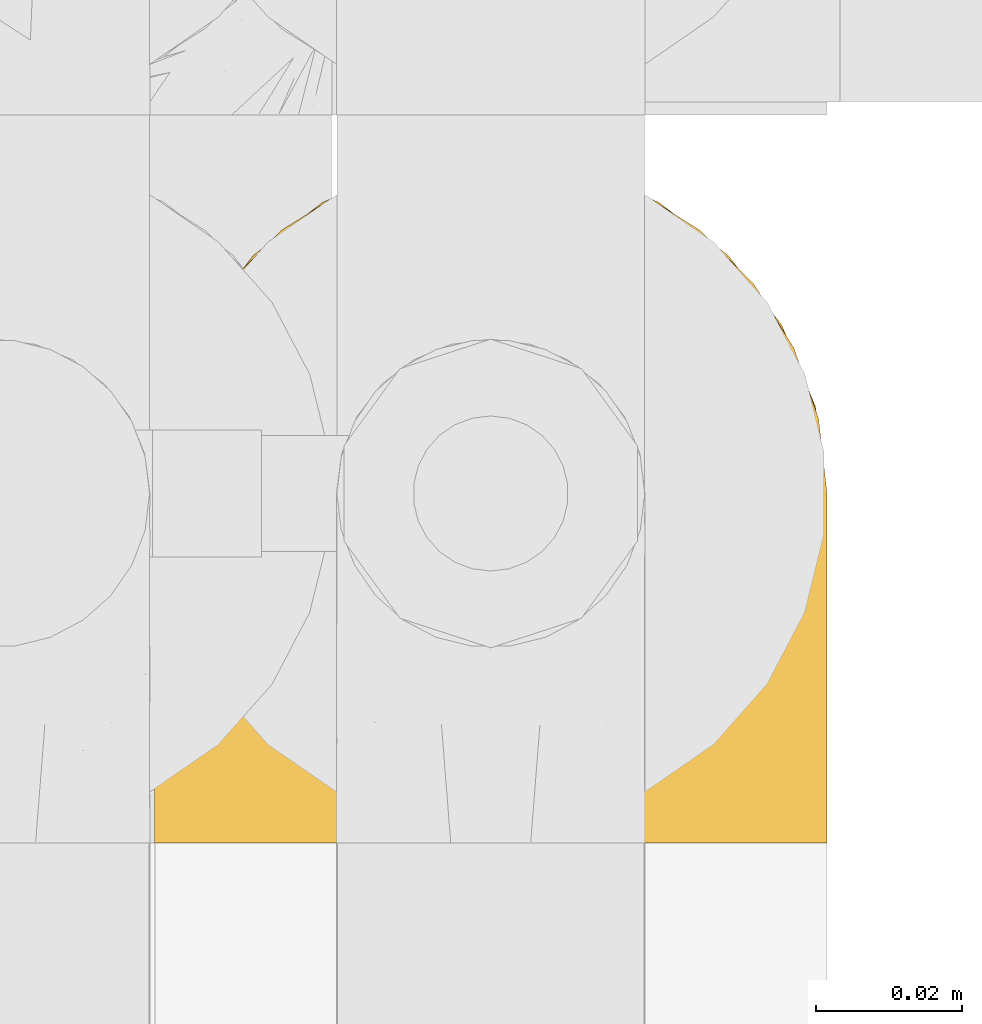
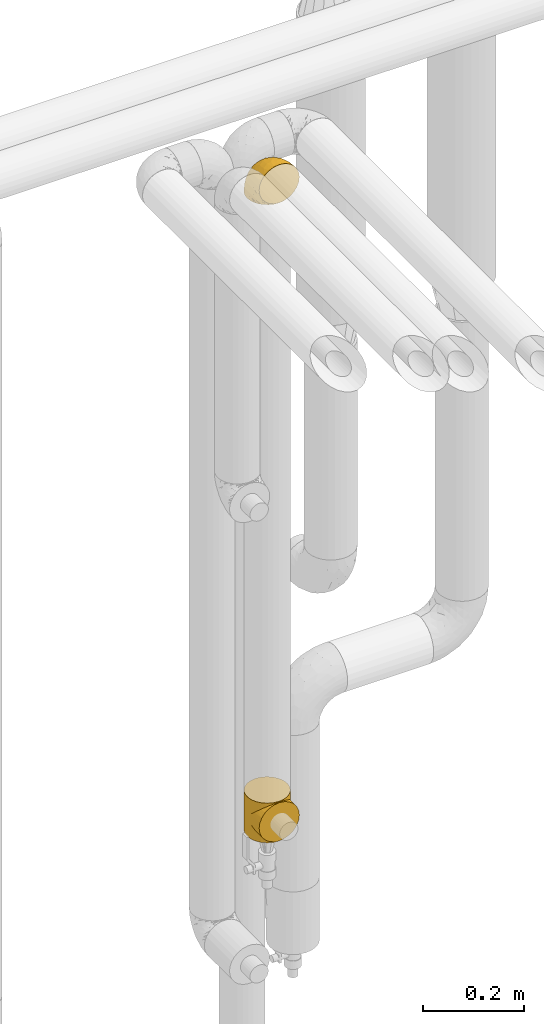
# One storey, part 308 of 827: 2 coverings.
"""IFC2X3 building model written with IfcOpenShell, lengths in millimetres."""

from ifc_helpers import new_model, entity, si_unit, converted_unit, derived_unit, direction, frame, origin, place, context, subcontext, project, spatial, faceted_brep, element, save


model = new_model("IFC2X3")

# Units and contexts
model_context = context("Model", 3, precision=0.01, world=origin(), true_north=direction((6.12303176911189e-17, 1.0)))
body_context = subcontext(model_context, "Body", "Model", "MODEL_VIEW")
ifc_project = project(units=[si_unit("LENGTHUNIT", "METRE", prefix="MILLI"), si_unit("AREAUNIT", "SQUARE_METRE"), si_unit("VOLUMEUNIT", "CUBIC_METRE"), converted_unit("PLANEANGLEUNIT", "DEGREE", entity("IfcRatioMeasure", 0.0174532925199433), si_unit("PLANEANGLEUNIT", "RADIAN"), dimensions=[0, 0, 0, 0, 0, 0, 0]), si_unit("MASSUNIT", "GRAM", prefix="KILO"), derived_unit("MASSDENSITYUNIT", [(si_unit("MASSUNIT", "GRAM", prefix="KILO"), 1), (si_unit("LENGTHUNIT", "METRE"), -3)]), derived_unit("MOMENTOFINERTIAUNIT", [(si_unit("LENGTHUNIT", "METRE"), 4)]), si_unit("TIMEUNIT", "SECOND"), si_unit("FREQUENCYUNIT", "HERTZ"), si_unit("THERMODYNAMICTEMPERATUREUNIT", "DEGREE_CELSIUS"), derived_unit("THERMALTRANSMITTANCEUNIT", [(si_unit("MASSUNIT", "GRAM", prefix="KILO"), 1), (si_unit("THERMODYNAMICTEMPERATUREUNIT", "KELVIN"), -1), (si_unit("TIMEUNIT", "SECOND"), -3)]), derived_unit("VOLUMETRICFLOWRATEUNIT", [(si_unit("LENGTHUNIT", "METRE"), 3), (si_unit("TIMEUNIT", "SECOND"), -1)]), derived_unit("MASSFLOWRATEUNIT", [(si_unit("MASSUNIT", "GRAM", prefix="KILO"), 1), (si_unit("TIMEUNIT", "SECOND"), -1)]), derived_unit("ROTATIONALFREQUENCYUNIT", [(si_unit("TIMEUNIT", "SECOND"), -1)]), si_unit("ELECTRICCURRENTUNIT", "AMPERE"), si_unit("ELECTRICVOLTAGEUNIT", "VOLT"), si_unit("POWERUNIT", "WATT"), si_unit("FORCEUNIT", "NEWTON", prefix="KILO"), si_unit("ILLUMINANCEUNIT", "LUX"), si_unit("LUMINOUSFLUXUNIT", "LUMEN"), si_unit("LUMINOUSINTENSITYUNIT", "CANDELA"), derived_unit("USERDEFINED", [(si_unit("MASSUNIT", "GRAM", prefix="KILO"), -1), (si_unit("LENGTHUNIT", "METRE"), -2), (si_unit("TIMEUNIT", "SECOND"), 3), (si_unit("LUMINOUSFLUXUNIT", "LUMEN"), 1)]), derived_unit("LINEARVELOCITYUNIT", [(si_unit("LENGTHUNIT", "METRE"), 1), (si_unit("TIMEUNIT", "SECOND"), -1)]), si_unit("PRESSUREUNIT", "PASCAL"), derived_unit("USERDEFINED", [(si_unit("LENGTHUNIT", "METRE"), -2), (si_unit("MASSUNIT", "GRAM", prefix="KILO"), 1), (si_unit("TIMEUNIT", "SECOND"), -2)]), derived_unit("LINEARFORCEUNIT", [(si_unit("MASSUNIT", "GRAM", prefix="KILO"), 1), (si_unit("LENGTHUNIT", "METRE"), 1), (si_unit("TIMEUNIT", "SECOND"), -2), (si_unit("LENGTHUNIT", "METRE"), -1)]), derived_unit("PLANARFORCEUNIT", [(si_unit("MASSUNIT", "GRAM", prefix="KILO"), 1), (si_unit("LENGTHUNIT", "METRE"), 1), (si_unit("TIMEUNIT", "SECOND"), -2), (si_unit("LENGTHUNIT", "METRE"), -2)])], contexts=[model_context])

# Site, building, storey
site_placement = place(None, origin())
site = spatial("IfcSite", under=ifc_project, at=site_placement, CompositionType="ELEMENT")
building_placement = place(site_placement, origin())
building = spatial("IfcBuilding", under=site, at=building_placement, CompositionType="ELEMENT")
storey_placement = place(building_placement, frame((0.0, 0.0, 28200.0)))
storey = spatial("IfcBuildingStorey", under=building, at=storey_placement, Name="08", CompositionType="ELEMENT", Elevation=28200.0)

# Coverings
covering_1_placement = place(storey_placement, frame((30677.28, 18291.61, 2950.4)))
element("IfcCovering", 1, at=covering_1_placement, inside=storey, Name=":ADSK_", ObjectType=":ADSK_", PredefinedType="INSULATION", context=body_context, shape_type="Brep", body=[
    faceted_brep([(11.68, 78.41, 1.6), (19.0, 85.72, 1.6), (27.76, 91.22, 1.6), (37.52, 94.64, 1.6), (47.8, 95.8, 1.6), (58.08, 94.64, 1.6), (67.85, 91.22, 1.6), (76.61, 85.71, 1.6), (83.92, 78.39, 1.6), (89.42, 69.63, 1.6), (92.84, 59.87, 1.6), (94.0, 49.6, 1.6), (93.53, 45.45, 1.6), (93.18, 42.38, 1.6), (92.84, 39.31, 1.6), (91.13, 34.43, 1.6), (89.42, 29.54, 1.6), (86.66, 25.16, 1.6), (83.91, 20.78, 1.6), (80.25, 17.13, 1.6), (76.59, 13.47, 1.6), (67.83, 7.97, 1.6), (62.95, 6.26, 1.6), (58.07, 4.55, 1.6), (47.8, 3.4, 1.6), (37.51, 4.55, 1.6), (32.63, 6.26, 1.6), (27.74, 7.97, 1.6), (18.98, 13.48, 1.6), (15.33, 17.14, 1.6), (11.67, 20.8, 1.6), (8.92, 25.18, 1.6), (6.17, 29.56, 1.6), (4.46, 34.44, 1.6), (2.75, 39.32, 1.6), (2.41, 42.39, 1.6), (2.06, 45.45, 1.6), (1.6, 49.6, 1.6), (2.75, 59.88, 1.6), (6.17, 69.65, 1.6), (47.8, 1.6, 3.4), (59.75, 1.6, 4.97), (70.9, 1.6, 9.58), (75.68, 1.6, 13.26), (80.46, 1.6, 16.93), (84.13, 1.6, 21.71), (87.81, 1.6, 26.5), (90.11, 1.6, 32.07), (92.42, 1.6, 37.64), (92.9, 1.6, 41.25), (93.17, 1.6, 43.34), (93.45, 1.6, 45.42), (94.0, 1.6, 49.6), (92.42, 1.6, 61.55), (87.81, 1.6, 72.7), (80.46, 1.6, 82.26), (70.9, 1.6, 89.61), (59.75, 1.6, 94.22), (47.8, 1.6, 95.8), (35.84, 1.6, 94.22), (24.7, 1.6, 89.61), (15.13, 1.6, 82.26), (7.78, 1.6, 72.7), (3.17, 1.6, 61.55), (1.6, 1.6, 49.6), (2.14, 1.6, 45.42), (2.69, 1.6, 41.25), (3.17, 1.6, 37.64), (5.48, 1.6, 32.07), (7.78, 1.6, 26.5), (11.46, 1.6, 21.71), (15.13, 1.6, 16.93), (19.91, 1.6, 13.26), (24.7, 1.6, 9.58), (35.84, 1.6, 4.97), (23.61, 36.81, 81.55), (31.99, 23.28, 90.4), (35.87, 45.8, 83.0), (47.8, 30.7, 91.18), (40.43, 21.2, 93.13), (47.8, 12.96, 94.0), (31.83, 66.19, 66.19), (23.37, 54.51, 70.92), (21.41, 17.98, 85.95), (3.07, 36.69, 49.74), (1.6, 35.54, 35.54), (1.6, 31.64, 38.14), (1.6, 27.75, 40.74), (1.6, 23.86, 43.34), (1.6, 19.96, 45.94), (13.45, 22.8, 77.59), (15.25, 42.67, 71.17), (8.07, 33.21, 65.81), (16.0, 59.45, 59.03), (17.34, 71.5, 45.85), (10.58, 62.66, 45.79), (5.34, 54.5, 41.42), (2.39, 47.57, 34.51), (8.36, 48.81, 56.04), (10.04, 74.98, 15.15), (2.59, 18.7, 56.51), (6.28, 15.75, 68.39), (34.28, 91.17, 23.33), (38.73, 85.28, 42.86), (27.25, 82.58, 39.42), (29.88, 75.78, 53.58), (38.6, 74.98, 59.17), (23.44, 67.27, 59.06), (25.25, 87.38, 22.63), (17.23, 82.04, 20.55), (47.8, 94.0, 12.96), (47.8, 77.8, 56.96), (47.8, 67.38, 67.38), (2.53, 56.2, 18.72), (1.6, 48.85, 5.33), (1.6, 48.11, 9.07), (1.6, 47.57, 11.79), (1.6, 47.03, 14.51), (1.6, 46.48, 17.24), (1.6, 45.94, 19.96), (5.71, 65.78, 21.03), (1.6, 17.24, 46.48), (1.6, 14.51, 47.03), (1.6, 11.79, 47.57), (1.6, 9.07, 48.11), (1.6, 7.2, 48.48), (1.6, 5.33, 48.85), (47.8, 91.18, 30.7), (1.6, 43.34, 23.86), (1.6, 40.74, 27.75), (1.6, 38.14, 31.64), (11.89, 72.73, 31.26), (47.8, 56.96, 77.8), (39.69, 62.23, 72.75), (47.8, 84.49, 43.83), (47.8, 43.83, 84.49), (13.84, 12.05, 14.58), (9.16, 18.95, 16.17), (15.79, 13.02, 10.82), (25.75, 8.34, 4.64), (16.09, 14.63, 7.71), (7.51, 11.09, 25.13), (3.99, 13.66, 32.66), (2.66, 20.08, 34.94), (3.16, 9.61, 36.76), (2.35, 9.48, 40.48), (2.23, 16.1, 39.25), (38.35, 3.42, 3.69), (6.18, 26.63, 13.99), (2.7, 33.72, 21.85), (2.93, 34.77, 17.93), (16.01, 6.75, 15.11), (9.08, 13.31, 21.14), (9.3, 21.11, 12.7), (11.68, 19.94, 7.21), (4.65, 8.67, 32.27), (3.65, 26.11, 25.68), (3.61, 29.3, 22.18), (12.8, 6.32, 18.79), (2.43, 39.92, 10.12), (6.83, 27.05, 9.47), (21.65, 6.04, 10.45), (3.7, 34.4, 11.29), (47.8, 2.87, 2.87), (3.37, 20.92, 31.16), (7.03, 27.43, 6.31), (7.87, 7.54, 25.62), (7.26, 18.45, 21.18), (3.41, 23.88, 28.81), (23.81, 7.77, 7.45), (86.5, 13.3, 21.14), (88.08, 11.09, 25.13), (82.79, 6.33, 18.79), (94.0, 9.07, 48.11), (94.0, 5.33, 48.85), (94.0, 14.51, 47.03), (94.0, 11.79, 47.57), (57.24, 3.42, 3.69), (71.76, 7.76, 7.44), (94.0, 47.03, 14.51), (94.0, 47.57, 11.79), (94.0, 48.85, 5.33), (94.0, 48.11, 9.07), (79.49, 14.62, 7.71), (88.75, 27.03, 9.47), (92.93, 20.08, 34.94), (92.22, 20.92, 31.16), (94.0, 27.75, 40.74), (94.0, 31.64, 38.14), (92.43, 9.61, 36.76), (93.24, 9.48, 40.48), (69.82, 8.33, 4.63), (79.57, 6.74, 15.11), (81.74, 12.04, 14.58), (94.0, 23.86, 43.34), (94.0, 19.96, 45.94), (93.36, 16.1, 39.25), (83.9, 19.93, 7.21), (86.28, 21.1, 12.69), (93.16, 39.92, 10.14), (92.88, 33.68, 21.81), (91.98, 29.28, 22.19), (89.41, 26.62, 14.0), (91.93, 26.08, 25.69), (86.42, 18.93, 16.17), (88.82, 27.87, 6.66), (92.66, 34.75, 17.92), (73.93, 6.04, 10.45), (94.0, 38.14, 31.64), (79.5, 12.79, 10.64), (91.89, 34.41, 11.31), (94.0, 45.94, 19.96), (94.0, 43.34, 23.86), (94.0, 40.74, 27.75), (91.6, 13.66, 32.66), (94.0, 17.24, 46.48), (90.94, 8.67, 32.27), (94.0, 35.54, 35.54), (92.16, 23.83, 28.77), (88.32, 18.43, 21.17), (86.13, 6.03, 23.36), (94.0, 46.48, 17.24), (93.2, 34.52, 47.58), (55.16, 21.2, 93.13), (82.02, 23.82, 77.44), (84.29, 41.32, 66.78), (76.94, 47.62, 71.68), (68.33, 52.66, 74.96), (71.98, 36.81, 81.55), (92.52, 49.75, 36.7), (92.9, 19.07, 56.9), (59.72, 45.8, 83.0), (63.6, 23.28, 90.4), (88.89, 21.35, 67.83), (74.18, 17.98, 85.95), (68.35, 82.57, 39.41), (61.33, 91.17, 23.33), (56.86, 85.27, 42.87), (68.62, 73.89, 53.92), (63.76, 66.19, 66.19), (72.19, 62.43, 64.12), (88.69, 63.53, 33.13), (92.19, 58.45, 23.1), (89.75, 67.16, 16.98), (59.86, 76.72, 55.72), (55.9, 62.22, 72.75), (77.99, 81.54, 23.77), (85.21, 74.8, 18.41), (74.99, 75.83, 43.7), (90.23, 41.45, 54.53), (70.75, 88.2, 17.73), (81.72, 71.6, 38.98), (86.53, 56.23, 50.28), (79.6, 59.44, 59.02)], [[[0, 1, 2, 3, 4, 5, 6, 7, 8, 9, 10, 11, 12, 13, 14, 15, 16, 17, 18, 19, 20, 21, 22, 23, 24, 25, 26, 27, 28, 29, 30, 31, 32, 33, 34, 35, 36, 37, 38, 39]], [[40, 41, 42, 43, 44, 45, 46, 47, 48, 49, 50, 51, 52, 53, 54, 55, 56, 57, 58, 59, 60, 61, 62, 63, 64, 65, 66, 67, 68, 69, 70, 71, 72, 73, 74]], [[75, 76, 77]], [[78, 79, 80]], [[77, 81, 82]], [[76, 75, 83]], [[84, 85, 86, 87, 88, 89]], [[90, 91, 92]], [[76, 60, 59]], [[93, 94, 95]], [[90, 62, 61]], [[83, 61, 60]], [[96, 97, 84]], [[98, 93, 95]], [[0, 39, 99]], [[100, 84, 89]], [[62, 101, 63]], [[2, 102, 3]], [[92, 84, 100]], [[103, 102, 104]], [[103, 105, 106]], [[93, 107, 94]], [[1, 108, 2]], [[92, 101, 90]], [[108, 1, 109]], [[102, 110, 3]], [[93, 82, 107]], [[102, 108, 104]], [[111, 106, 112]], [[109, 0, 99]], [[113, 37, 114, 115, 116, 117, 118, 119]], [[120, 38, 113]], [[100, 89, 121, 122, 123, 124, 125, 126, 64]], [[127, 102, 103]], [[97, 119, 128, 129, 130, 85]], [[99, 120, 131]], [[132, 133, 77]], [[59, 80, 79]], [[1, 0, 109]], [[98, 84, 92]], [[94, 109, 131]], [[120, 39, 38]], [[93, 91, 82]], [[104, 94, 105]], [[97, 113, 119]], [[95, 120, 96]], [[83, 90, 61]], [[91, 93, 98]], [[64, 63, 100]], [[100, 63, 101]], [[77, 76, 79]], [[133, 106, 81]], [[84, 97, 85]], [[113, 96, 120]], [[113, 97, 96]], [[37, 113, 38]], [[110, 102, 127]], [[110, 4, 3]], [[103, 111, 134, 127]], [[90, 75, 91]], [[82, 81, 107]], [[91, 75, 82]], [[77, 82, 75]], [[76, 83, 60]], [[90, 83, 75]], [[105, 107, 81]], [[94, 131, 95]], [[105, 94, 107]], [[109, 94, 104]], [[120, 95, 131]], [[98, 95, 96]], [[84, 98, 96]], [[98, 92, 91]], [[106, 105, 81]], [[103, 104, 105]], [[112, 106, 133]], [[103, 106, 111]], [[112, 133, 132]], [[81, 77, 133]], [[77, 78, 135, 132]], [[120, 99, 39]], [[109, 99, 131]], [[59, 58, 80]], [[59, 79, 76]], [[90, 101, 62]], [[100, 101, 92]], [[2, 108, 102]], [[109, 104, 108]], [[78, 77, 79]], [[136, 137, 138]], [[27, 139, 140]], [[141, 142, 143]], [[144, 145, 121]], [[146, 89, 88]], [[147, 139, 25]], [[148, 149, 150]], [[136, 151, 152]], [[147, 40, 74]], [[24, 147, 25]], [[140, 153, 154]], [[33, 116, 34]], [[73, 72, 151]], [[114, 37, 36, 35, 34, 116, 115]], [[146, 155, 144]], [[156, 85, 130]], [[157, 149, 148]], [[151, 158, 152]], [[117, 33, 159]], [[29, 154, 160]], [[161, 74, 73]], [[162, 128, 119]], [[66, 65, 64, 126, 125, 124, 123, 122, 67]], [[163, 147, 24]], [[27, 140, 28]], [[149, 129, 150]], [[139, 27, 26, 25]], [[68, 144, 69]], [[129, 128, 150]], [[164, 87, 86]], [[130, 129, 149]], [[122, 145, 67]], [[154, 153, 148]], [[162, 119, 159]], [[165, 30, 160]], [[150, 160, 148]], [[128, 162, 150]], [[30, 165, 31]], [[145, 144, 68]], [[89, 146, 144]], [[87, 164, 143]], [[166, 155, 142]], [[88, 87, 143]], [[162, 160, 150]], [[160, 30, 29]], [[154, 29, 28]], [[140, 154, 28]], [[160, 154, 148]], [[140, 137, 153]], [[157, 148, 153]], [[156, 130, 157]], [[153, 137, 157]], [[157, 137, 156]], [[167, 137, 136]], [[168, 85, 156]], [[152, 168, 167]], [[167, 168, 156]], [[164, 152, 141]], [[71, 158, 72]], [[152, 167, 136]], [[88, 142, 146]], [[144, 155, 69]], [[146, 142, 155]], [[70, 166, 71]], [[142, 141, 166]], [[70, 69, 155]], [[141, 158, 71]], [[161, 73, 151]], [[138, 137, 140]], [[161, 136, 169]], [[136, 161, 151]], [[74, 161, 169]], [[152, 158, 141]], [[151, 72, 158]], [[168, 152, 164]], [[137, 167, 156]], [[164, 86, 168]], [[85, 168, 86]], [[116, 33, 117]], [[130, 149, 157]], [[67, 145, 68]], [[121, 89, 144]], [[145, 122, 121]], [[40, 147, 163]], [[169, 147, 74]], [[159, 33, 32]], [[162, 159, 32]], [[159, 119, 118, 117]], [[139, 147, 169]], [[139, 169, 138]], [[162, 32, 31]], [[141, 143, 164]], [[88, 143, 142]], [[71, 166, 141]], [[155, 166, 70]], [[139, 138, 140]], [[169, 136, 138]], [[160, 162, 165]], [[162, 31, 165]], [[170, 171, 172]], [[173, 174, 52, 51, 50, 49, 48, 175, 176]], [[177, 178, 41]], [[179, 15, 180]], [[12, 11, 181, 182, 180, 14, 13]], [[183, 21, 20]], [[19, 18, 184]], [[185, 186, 187]], [[186, 188, 187]], [[43, 172, 44]], [[189, 190, 47]], [[23, 22, 21, 191]], [[170, 192, 193]], [[40, 163, 177]], [[194, 195, 196]], [[24, 23, 177]], [[197, 198, 183]], [[199, 15, 179]], [[47, 46, 189]], [[200, 201, 202]], [[201, 203, 204]], [[205, 206, 184]], [[207, 41, 178]], [[16, 15, 199]], [[14, 180, 15]], [[202, 201, 198]], [[208, 201, 200]], [[163, 24, 177]], [[48, 47, 190]], [[196, 195, 189]], [[197, 184, 202]], [[204, 193, 209]], [[210, 211, 212]], [[206, 212, 213]], [[205, 17, 210]], [[184, 206, 202]], [[210, 212, 206]], [[185, 194, 214]], [[189, 215, 190]], [[216, 45, 214]], [[186, 171, 170]], [[189, 216, 196]], [[197, 20, 19]], [[194, 185, 187]], [[197, 183, 20]], [[184, 197, 19]], [[197, 202, 198]], [[206, 200, 202]], [[204, 183, 198]], [[201, 208, 203]], [[203, 208, 217]], [[204, 198, 201]], [[217, 188, 218]], [[193, 219, 170]], [[171, 186, 185]], [[170, 218, 186]], [[170, 219, 218]], [[42, 207, 192]], [[171, 220, 172]], [[216, 189, 46]], [[214, 194, 196]], [[44, 220, 45]], [[214, 196, 216]], [[216, 46, 45]], [[214, 45, 220]], [[192, 43, 42]], [[204, 203, 219]], [[207, 193, 192]], [[209, 193, 178]], [[41, 207, 42]], [[193, 207, 178]], [[43, 192, 172]], [[170, 172, 192]], [[204, 219, 193]], [[219, 203, 218]], [[217, 218, 203]], [[188, 186, 218]], [[206, 213, 200]], [[208, 200, 213]], [[199, 210, 16]], [[215, 189, 195]], [[215, 175, 190]], [[175, 48, 190]], [[199, 179, 221, 211]], [[210, 199, 211]], [[23, 191, 177]], [[40, 177, 41]], [[178, 177, 191]], [[21, 183, 191]], [[209, 191, 183]], [[205, 18, 17]], [[17, 16, 210]], [[171, 185, 214]], [[172, 220, 44]], [[214, 220, 171]], [[191, 209, 178]], [[204, 209, 183]], [[206, 205, 210]], [[18, 205, 184]], [[222, 195, 194, 187, 188, 217]], [[57, 223, 80]], [[224, 225, 226]], [[226, 227, 228]], [[229, 217, 208, 213, 212, 211]], [[230, 52, 174, 173, 176, 175, 215, 195]], [[231, 232, 228]], [[231, 78, 223]], [[223, 57, 232]], [[224, 233, 225]], [[233, 54, 53]], [[234, 232, 56]], [[56, 55, 234]], [[234, 224, 228]], [[235, 236, 237]], [[224, 55, 54]], [[238, 239, 240]], [[52, 230, 53]], [[241, 242, 243]], [[239, 244, 245]], [[11, 10, 242]], [[236, 6, 5]], [[7, 246, 8]], [[8, 247, 9]], [[238, 248, 235]], [[222, 229, 249]], [[242, 211, 221, 179, 180, 182, 181, 11]], [[233, 53, 230]], [[111, 112, 244]], [[250, 6, 236]], [[247, 251, 241]], [[6, 250, 7]], [[127, 236, 110]], [[249, 229, 252]], [[247, 8, 246]], [[235, 246, 250]], [[236, 5, 110]], [[235, 244, 238]], [[237, 236, 127]], [[243, 9, 247]], [[252, 229, 241]], [[56, 232, 57]], [[222, 230, 195]], [[225, 249, 252]], [[249, 233, 230]], [[54, 233, 224]], [[231, 228, 227]], [[245, 132, 231]], [[249, 225, 233]], [[226, 225, 253]], [[235, 250, 236]], [[246, 7, 250]], [[251, 247, 246]], [[243, 247, 241]], [[248, 246, 235]], [[252, 251, 253]], [[229, 222, 217]], [[230, 222, 249]], [[5, 4, 110]], [[237, 127, 134, 111]], [[238, 244, 239]], [[224, 234, 55]], [[232, 234, 228]], [[242, 241, 229]], [[10, 9, 243]], [[211, 242, 229]], [[10, 243, 242]], [[80, 223, 78]], [[80, 58, 57]], [[231, 223, 232]], [[227, 240, 239]], [[224, 226, 228]], [[240, 226, 253]], [[227, 239, 245]], [[226, 240, 227]], [[251, 248, 253]], [[240, 253, 248]], [[244, 235, 237]], [[237, 111, 244]], [[132, 245, 112]], [[112, 245, 244]], [[135, 78, 231, 132]], [[227, 245, 231]], [[248, 238, 240]], [[246, 248, 251]], [[251, 252, 241]], [[225, 252, 253]]]),
])
covering_2_placement = place(storey_placement, frame((30677.28, 18293.2, 1404.5)))
element("IfcCovering", 2, at=covering_2_placement, inside=storey, Name=":ADSK_", ObjectType=":ADSK_", PredefinedType="INSULATION", context=body_context, shape_type="Brep", body=[
    faceted_brep([(61.93, 4.27, 4.27), (59.75, 3.37, 0.0), (62.54, 4.53, 0.0), (52.28, 2.39, 0.0), (53.77, 2.59, 0.0), (52.64, 2.31, 2.31), (59.7, 3.55, 3.55), (58.59, 3.19, 3.19), (65.32, 5.68, 0.0), (66.38, 5.7, 5.7), (64.16, 4.98, 4.98), (57.48, 2.83, 2.83), (56.76, 2.98, 0.0), (58.26, 3.18, 0.0), (68.11, 6.84, 0.0), (70.9, 7.99, 0.0), (70.23, 7.85, 7.85), (74.07, 10.0, 10.0), (75.68, 11.66, 0.0), (80.41, 15.27, 15.27), (50.22, 2.06, 2.06), (49.29, 2.0, 0.0), (50.04, 2.1, 0.0), (50.78, 2.19, 0.0), (80.46, 15.33, 0.0), (85.44, 21.21, 21.21), (87.81, 24.9, 0.0), (55.06, 2.57, 2.57), (53.85, 2.44, 2.44), (89.25, 27.6, 27.6), (92.42, 36.04, 0.0), (56.27, 2.7, 2.7), (55.27, 2.78, 0.0), (93.48, 41.09, 41.09), (94.0, 48.0, 0.0), (91.9, 34.26, 34.26), (94.0, 48.0, 48.0), (93.48, 41.09, 54.91), (94.0, 48.0, 96.0), (49.01, 1.93, 1.93), (47.8, 1.8, 0.0), (51.43, 2.18, 2.18), (51.53, 2.29, 0.0), (47.8, 1.8, 1.8), (49.01, 1.93, 94.07), (47.8, 1.8, 96.0), (47.8, 1.8, 94.2), (2.11, 41.09, 41.09), (1.6, 48.0, 0.0), (3.17, 36.04, 0.0), (25.36, 7.85, 7.85), (27.48, 6.84, 0.0), (29.21, 5.7, 5.7), (7.78, 24.9, 0.0), (6.34, 27.6, 27.6), (10.15, 21.22, 21.22), (15.13, 15.33, 0.0), (24.7, 7.99, 0.0), (35.84, 3.37, 0.0), (37.01, 3.18, 3.18), (35.9, 3.54, 3.54), (33.67, 4.26, 4.26), (1.6, 48.0, 48.0), (2.11, 41.09, 54.91), (1.6, 48.0, 96.0), (38.13, 2.82, 2.82), (37.33, 3.18, 0.0), (38.83, 2.98, 0.0), (3.68, 34.26, 34.26), (44.06, 2.29, 0.0), (44.81, 2.19, 0.0), (44.17, 2.18, 2.18), (43.31, 2.39, 0.0), (21.52, 10.0, 10.0), (19.91, 11.66, 0.0), (33.05, 4.53, 0.0), (31.44, 4.98, 4.98), (30.27, 5.68, 0.0), (46.3, 2.0, 0.0), (46.59, 1.93, 1.93), (45.38, 2.06, 2.06), (42.96, 2.31, 2.31), (40.32, 2.78, 0.0), (41.82, 2.59, 0.0), (40.54, 2.57, 2.57), (15.18, 15.28, 15.28), (39.33, 2.7, 2.7), (41.75, 2.44, 2.44), (46.59, 1.93, 94.07), (45.55, 2.1, 0.0), (70.9, 88.01, 96.0), (59.75, 92.63, 96.0), (47.8, 94.2, 96.0), (35.84, 92.63, 96.0), (24.7, 88.01, 96.0), (15.13, 80.67, 96.0), (7.78, 71.1, 96.0), (3.17, 59.96, 96.0), (3.17, 36.04, 96.0), (7.78, 24.9, 96.0), (15.13, 15.33, 96.0), (19.91, 11.66, 96.0), (24.7, 7.99, 96.0), (27.48, 6.84, 96.0), (30.27, 5.68, 96.0), (33.05, 4.53, 96.0), (35.84, 3.37, 96.0), (37.33, 3.18, 96.0), (38.83, 2.98, 96.0), (40.32, 2.78, 96.0), (41.82, 2.59, 96.0), (43.31, 2.39, 96.0), (44.06, 2.29, 96.0), (44.81, 2.19, 96.0), (45.55, 2.1, 96.0), (46.3, 2.0, 96.0), (49.29, 2.0, 96.0), (50.04, 2.1, 96.0), (50.78, 2.19, 96.0), (51.53, 2.29, 96.0), (52.28, 2.39, 96.0), (53.77, 2.59, 96.0), (55.27, 2.78, 96.0), (56.76, 2.98, 96.0), (58.26, 3.18, 96.0), (59.75, 3.37, 96.0), (62.54, 4.53, 96.0), (65.32, 5.68, 96.0), (68.11, 6.84, 96.0), (70.9, 7.99, 96.0), (75.68, 11.66, 96.0), (80.46, 15.33, 96.0), (87.81, 24.9, 96.0), (92.42, 36.04, 96.0), (92.42, 59.96, 96.0), (87.81, 71.1, 96.0), (80.46, 80.67, 96.0), (3.17, 59.96, 0.0), (7.78, 71.1, 0.0), (15.13, 80.67, 0.0), (24.7, 88.01, 0.0), (35.84, 92.63, 0.0), (47.8, 94.2, 0.0), (59.75, 92.63, 0.0), (70.9, 88.01, 0.0), (80.46, 80.67, 0.0), (87.81, 71.1, 0.0), (92.42, 59.96, 0.0), (33.67, 4.26, 91.74), (35.9, 3.54, 92.46), (37.01, 3.18, 92.82), (3.68, 34.26, 61.74), (6.34, 27.6, 68.4), (29.21, 5.7, 90.3), (39.33, 2.7, 93.3), (40.54, 2.57, 93.43), (10.15, 21.22, 74.78), (21.52, 10.0, 86.0), (25.36, 7.85, 88.15), (15.18, 15.28, 80.72), (31.44, 4.98, 91.02), (38.13, 2.82, 93.18), (45.38, 2.06, 93.94), (41.75, 2.44, 93.56), (42.96, 2.31, 93.69), (44.17, 2.18, 93.82), (66.38, 5.7, 90.3), (64.16, 4.98, 91.02), (74.07, 10.0, 86.0), (55.06, 2.57, 93.43), (80.41, 15.27, 80.73), (70.23, 7.85, 88.15), (56.27, 2.7, 93.3), (57.48, 2.83, 93.17), (51.43, 2.18, 93.82), (52.64, 2.31, 93.69), (61.93, 4.27, 91.73), (58.59, 3.19, 92.81), (59.7, 3.55, 92.45), (89.25, 27.6, 68.4), (91.9, 34.26, 61.74), (85.44, 21.21, 74.79), (53.85, 2.44, 93.56), (50.22, 2.06, 93.94), (1.6, 0.0, 48.0), (3.17, 0.0, 36.04), (7.78, 0.0, 24.9), (15.13, 0.0, 15.33), (19.91, 0.0, 11.66), (24.7, 0.0, 7.99), (27.48, 0.0, 6.84), (30.27, 0.0, 5.68), (33.05, 0.0, 4.53), (35.84, 0.0, 3.37), (37.33, 0.0, 3.18), (38.83, 0.0, 2.98), (40.32, 0.0, 2.78), (41.82, 0.0, 2.59), (43.31, 0.0, 2.39), (44.06, 0.0, 2.29), (44.81, 0.0, 2.19), (45.55, 0.0, 2.1), (46.3, 0.0, 2.0), (47.8, 0.0, 1.8), (49.29, 0.0, 2.0), (50.04, 0.0, 2.1), (50.78, 0.0, 2.19), (51.53, 0.0, 2.29), (52.28, 0.0, 2.39), (53.77, 0.0, 2.59), (55.27, 0.0, 2.78), (56.76, 0.0, 2.98), (58.26, 0.0, 3.18), (59.75, 0.0, 3.37), (62.54, 0.0, 4.53), (65.32, 0.0, 5.68), (68.11, 0.0, 6.84), (70.9, 0.0, 7.99), (75.68, 0.0, 11.66), (80.46, 0.0, 15.33), (87.81, 0.0, 24.9), (92.42, 0.0, 36.04), (94.0, 0.0, 48.0), (92.42, 0.0, 59.96), (87.81, 0.0, 71.1), (80.46, 0.0, 80.67), (75.68, 0.0, 84.34), (70.9, 0.0, 88.01), (68.11, 0.0, 89.16), (65.32, 0.0, 90.32), (62.54, 0.0, 91.47), (59.75, 0.0, 92.63), (58.26, 0.0, 92.82), (56.76, 0.0, 93.02), (55.27, 0.0, 93.22), (53.77, 0.0, 93.41), (52.28, 0.0, 93.61), (51.53, 0.0, 93.71), (50.78, 0.0, 93.81), (50.04, 0.0, 93.9), (49.29, 0.0, 94.0), (47.8, 0.0, 94.2), (46.3, 0.0, 94.0), (45.55, 0.0, 93.9), (44.81, 0.0, 93.81), (44.06, 0.0, 93.71), (43.31, 0.0, 93.61), (41.82, 0.0, 93.41), (40.32, 0.0, 93.22), (38.83, 0.0, 93.02), (37.33, 0.0, 92.82), (35.84, 0.0, 92.63), (33.05, 0.0, 91.47), (30.27, 0.0, 90.32), (27.48, 0.0, 89.16), (24.7, 0.0, 88.01), (19.91, 0.0, 84.34), (15.13, 0.0, 80.67), (7.78, 0.0, 71.1), (3.17, 0.0, 59.96)], [[[0, 1, 2]], [[3, 4, 5]], [[1, 0, 6, 7]], [[8, 9, 10]], [[11, 12, 13]], [[14, 15, 16]], [[2, 10, 0]], [[11, 13, 7]], [[17, 15, 18]], [[19, 17, 18]], [[14, 16, 9]], [[20, 21, 22, 23]], [[18, 24, 19]], [[15, 17, 16]], [[25, 24, 26]], [[4, 27, 28, 5]], [[29, 26, 30]], [[31, 32, 12]], [[12, 11, 31]], [[33, 30, 34]], [[32, 31, 27]], [[29, 25, 26]], [[33, 35, 30]], [[36, 33, 34]], [[37, 36, 38]], [[9, 8, 14]], [[29, 30, 35]], [[10, 2, 8]], [[1, 7, 13]], [[24, 25, 19]], [[27, 4, 32]], [[39, 40, 21]], [[41, 3, 5]], [[23, 41, 20]], [[3, 41, 23, 42]], [[40, 39, 43]], [[44, 45, 46]], [[21, 20, 39]], [[47, 48, 49]], [[50, 51, 52]], [[49, 53, 54]], [[55, 53, 56]], [[51, 50, 57]], [[55, 54, 53]], [[58, 59, 60, 61]], [[47, 62, 48]], [[62, 63, 64]], [[65, 66, 67]], [[54, 68, 49]], [[47, 49, 68]], [[66, 65, 59]], [[59, 58, 66]], [[69, 70, 71, 72]], [[73, 74, 57]], [[75, 76, 77]], [[75, 58, 61]], [[78, 79, 80]], [[76, 75, 61]], [[81, 72, 71]], [[82, 83, 84]], [[85, 56, 74]], [[85, 74, 73]], [[52, 77, 76]], [[67, 86, 65]], [[52, 51, 77]], [[73, 57, 50]], [[82, 86, 67]], [[56, 85, 55]], [[83, 81, 87, 84]], [[81, 83, 72]], [[86, 82, 84]], [[79, 40, 43]], [[45, 88, 46]], [[70, 80, 71]], [[80, 70, 89, 78]], [[40, 79, 78]], [[90, 91, 92, 93, 94, 95, 96, 97, 64, 98, 99, 100, 101, 102, 103, 104, 105, 106, 107, 108, 109, 110, 111, 112, 113, 114, 115, 45, 116, 117, 118, 119, 120, 121, 122, 123, 124, 125, 126, 127, 128, 129, 130, 131, 132, 133, 38, 134, 135, 136]], [[48, 137, 138, 139, 140, 141, 142, 143, 144, 145, 146, 147, 34, 30, 26, 24, 18, 15, 14, 8, 2, 1, 13, 12, 32, 4, 3, 42, 23, 22, 21, 40, 78, 89, 70, 69, 72, 83, 82, 67, 66, 58, 75, 77, 51, 57, 74, 56, 53, 49]], [[140, 139, 95, 94]], [[92, 142, 141, 93]], [[141, 140, 94, 93]], [[96, 138, 137, 97]], [[48, 62, 64, 97, 137]], [[95, 139, 138, 96]], [[106, 148, 149, 150]], [[151, 152, 98]], [[153, 104, 103]], [[148, 106, 105]], [[63, 151, 98]], [[109, 154, 155]], [[64, 63, 98]], [[99, 156, 100]], [[99, 98, 152]], [[156, 99, 152]], [[102, 157, 158]], [[106, 150, 107]], [[155, 110, 109]], [[157, 101, 159]], [[105, 160, 148]], [[161, 107, 150]], [[162, 115, 114, 113]], [[157, 102, 101]], [[153, 103, 158]], [[104, 153, 160]], [[159, 101, 100]], [[102, 158, 103]], [[108, 161, 154]], [[110, 155, 163, 164]], [[164, 111, 110]], [[161, 108, 107]], [[160, 105, 104]], [[159, 100, 156]], [[154, 109, 108]], [[88, 45, 115]], [[165, 111, 164]], [[113, 165, 162]], [[111, 165, 113, 112]], [[115, 162, 88]], [[166, 127, 167]], [[166, 128, 127]], [[129, 168, 130]], [[122, 121, 169]], [[170, 130, 168]], [[171, 168, 129]], [[123, 172, 173]], [[119, 118, 174, 120]], [[128, 171, 129]], [[174, 175, 120]], [[126, 125, 176]], [[171, 128, 166]], [[170, 131, 130]], [[125, 177, 178, 176]], [[179, 180, 133]], [[173, 124, 123]], [[177, 125, 124]], [[180, 37, 133]], [[131, 181, 132]], [[181, 131, 170]], [[179, 132, 181]], [[179, 133, 132]], [[121, 175, 182, 169]], [[167, 126, 176]], [[37, 38, 133]], [[126, 167, 127]], [[122, 172, 123]], [[124, 173, 177]], [[116, 44, 183]], [[175, 121, 120]], [[172, 122, 169]], [[118, 183, 174]], [[183, 118, 117, 116]], [[45, 44, 116]], [[36, 34, 147, 134, 38]], [[134, 147, 146, 135]], [[146, 145, 136, 135]], [[136, 145, 144, 90]], [[90, 144, 143, 91]], [[91, 143, 142, 92]], [[184, 185, 186, 187, 188, 189, 190, 191, 192, 193, 194, 195, 196, 197, 198, 199, 200, 201, 202, 203, 204, 205, 206, 207, 208, 209, 210, 211, 212, 213, 214, 215, 216, 217, 218, 219, 220, 221, 222, 223, 224, 225, 226, 227, 228, 229, 230, 231, 232, 233, 234, 235, 236, 237, 238, 239, 240, 241, 242, 243, 244, 245, 246, 247, 248, 249, 250, 251, 252, 253, 254, 255, 256, 257, 258, 259]], [[86, 196, 195]], [[198, 197, 81]], [[193, 61, 60, 59]], [[52, 191, 190]], [[61, 193, 192]], [[190, 189, 50]], [[192, 76, 61]], [[65, 194, 59]], [[73, 189, 188]], [[85, 73, 188]], [[190, 50, 52]], [[80, 202, 201, 200]], [[188, 187, 85]], [[189, 73, 50]], [[55, 187, 186]], [[76, 192, 191]], [[54, 186, 185]], [[193, 59, 194]], [[47, 185, 184]], [[191, 52, 76]], [[54, 55, 186]], [[197, 84, 87, 81]], [[47, 68, 185]], [[62, 47, 184]], [[65, 195, 194]], [[54, 185, 68]], [[196, 86, 84]], [[187, 55, 85]], [[84, 197, 196]], [[195, 65, 86]], [[79, 203, 202]], [[71, 198, 81]], [[200, 71, 80]], [[198, 71, 200, 199]], [[203, 79, 43]], [[202, 80, 79]], [[63, 184, 259]], [[158, 254, 153]], [[259, 258, 152]], [[156, 258, 257]], [[254, 158, 255]], [[156, 152, 258]], [[251, 150, 149, 148]], [[63, 62, 184]], [[161, 250, 249]], [[152, 151, 259]], [[63, 259, 151]], [[250, 161, 150]], [[150, 251, 250]], [[245, 244, 165, 246]], [[157, 256, 255]], [[252, 160, 253]], [[252, 251, 148]], [[242, 88, 162]], [[160, 252, 148]], [[164, 246, 165]], [[248, 247, 155]], [[159, 257, 256]], [[159, 256, 157]], [[153, 253, 160]], [[249, 154, 161]], [[153, 254, 253]], [[157, 255, 158]], [[248, 154, 249]], [[257, 159, 156]], [[247, 164, 163, 155]], [[164, 247, 246]], [[154, 248, 155]], [[88, 241, 46]], [[244, 162, 165]], [[162, 244, 243, 242]], [[241, 88, 242]], [[176, 231, 230]], [[236, 235, 175]], [[231, 176, 178, 177]], [[229, 166, 167]], [[173, 233, 232]], [[228, 227, 171]], [[230, 167, 176]], [[173, 232, 177]], [[168, 227, 226]], [[170, 168, 226]], [[228, 171, 166]], [[183, 240, 239, 238]], [[226, 225, 170]], [[227, 168, 171]], [[181, 225, 224]], [[235, 169, 182, 175]], [[179, 224, 223]], [[172, 234, 233]], [[233, 173, 172]], [[37, 223, 222]], [[234, 172, 169]], [[179, 181, 224]], [[37, 180, 223]], [[36, 37, 222]], [[166, 229, 228]], [[179, 223, 180]], [[167, 230, 229]], [[231, 177, 232]], [[225, 181, 170]], [[169, 235, 234]], [[44, 241, 240]], [[174, 236, 175]], [[238, 174, 183]], [[236, 174, 238, 237]], [[241, 44, 46]], [[240, 183, 44]], [[33, 222, 221]], [[209, 5, 28, 27]], [[221, 220, 29]], [[25, 220, 219]], [[210, 31, 211]], [[25, 29, 220]], [[16, 216, 9]], [[33, 36, 222]], [[7, 213, 212]], [[29, 35, 221]], [[33, 221, 35]], [[11, 212, 211]], [[216, 16, 217]], [[207, 206, 41, 208]], [[17, 218, 217]], [[204, 39, 20]], [[214, 213, 0]], [[10, 214, 0]], [[212, 11, 7]], [[5, 208, 41]], [[210, 209, 27]], [[19, 219, 218]], [[19, 218, 17]], [[9, 215, 10]], [[211, 31, 11]], [[9, 216, 215]], [[17, 217, 16]], [[213, 7, 6, 0]], [[219, 19, 25]], [[214, 10, 215]], [[5, 209, 208]], [[31, 210, 27]], [[39, 203, 43]], [[206, 20, 41]], [[20, 206, 205, 204]], [[203, 39, 204]]]),
])

save(model, "model.ifc")
